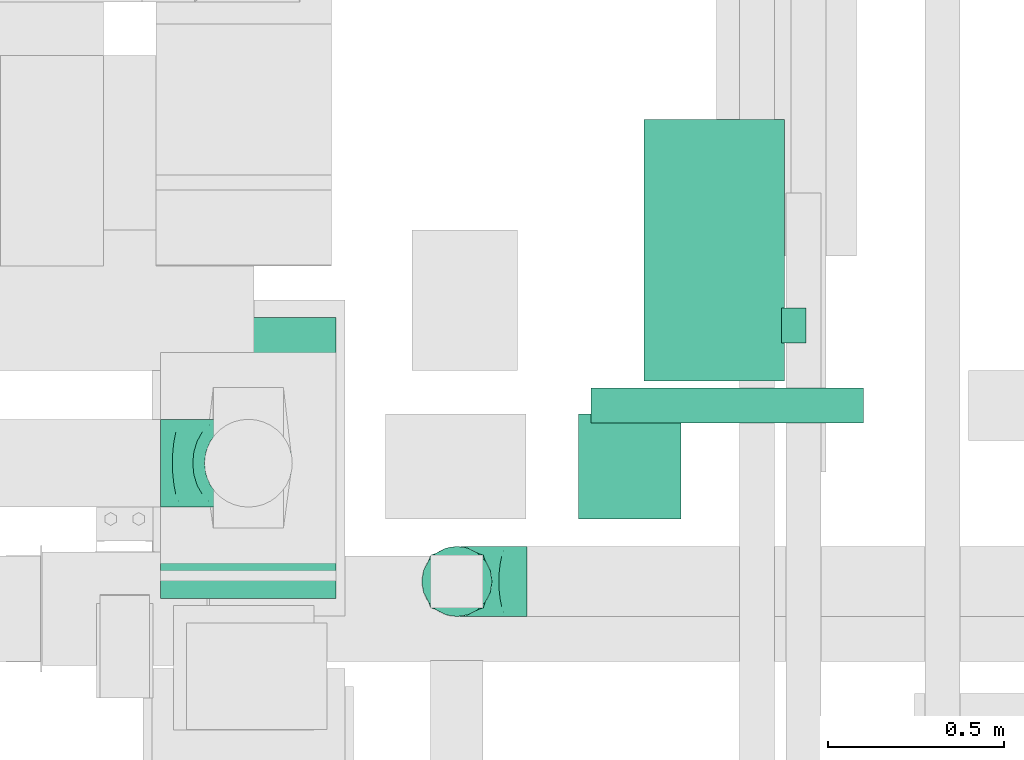
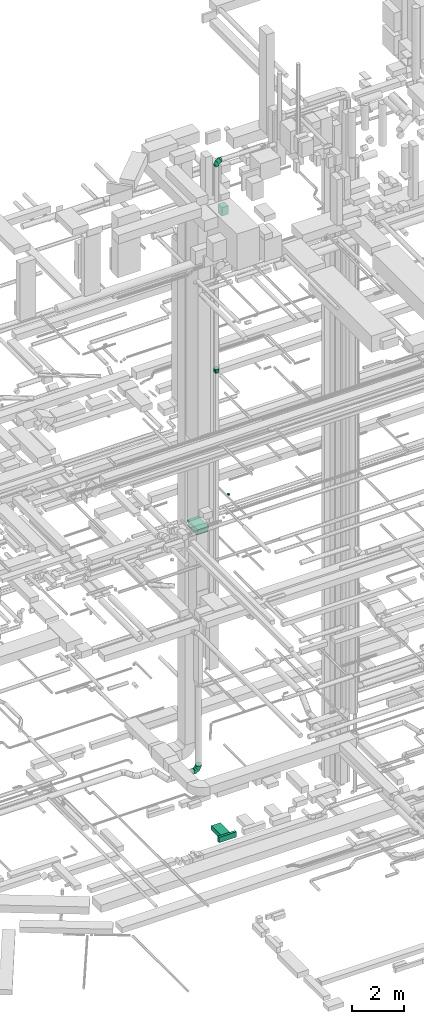
# One storey, part 129 of 337: 4 flow fittings, 4 flow segments.
"""IFC2X3 building model written with IfcOpenShell, lengths in millimetres."""

from ifc_helpers import new_model, entity, si_unit, converted_unit, derived_unit, direction, frame, origin, origin_2d_with_axis, place, context, subcontext, project, spatial, polyline, rectangle, circle, outline, extrude, faceted_brep, source, transform, mapped, material, type_object, type_shapes, element, save


model = new_model("IFC2X3")

# Units and contexts
model_context = context("Model", 3, precision=0.01, world=origin(), true_north=direction((6.12303176911189e-17, 1.0)))
body_context = subcontext(model_context, "Body", "Model", "MODEL_VIEW")
ifc_project = project(units=[si_unit("LENGTHUNIT", "METRE", prefix="MILLI"), si_unit("AREAUNIT", "SQUARE_METRE"), si_unit("VOLUMEUNIT", "CUBIC_METRE"), converted_unit("PLANEANGLEUNIT", "DEGREE", entity("IfcRatioMeasure", 0.0174532925199433), si_unit("PLANEANGLEUNIT", "RADIAN"), dimensions=[0, 0, 0, 0, 0, 0, 0]), si_unit("MASSUNIT", "GRAM", prefix="KILO"), derived_unit("MASSDENSITYUNIT", [(si_unit("MASSUNIT", "GRAM", prefix="KILO"), 1), (si_unit("LENGTHUNIT", "METRE"), -3)]), derived_unit("MOMENTOFINERTIAUNIT", [(si_unit("LENGTHUNIT", "METRE"), 4)]), si_unit("TIMEUNIT", "SECOND"), si_unit("FREQUENCYUNIT", "HERTZ"), si_unit("THERMODYNAMICTEMPERATUREUNIT", "DEGREE_CELSIUS"), derived_unit("THERMALTRANSMITTANCEUNIT", [(si_unit("MASSUNIT", "GRAM", prefix="KILO"), 1), (si_unit("THERMODYNAMICTEMPERATUREUNIT", "KELVIN"), -1), (si_unit("TIMEUNIT", "SECOND"), -3)]), derived_unit("VOLUMETRICFLOWRATEUNIT", [(si_unit("LENGTHUNIT", "METRE"), 3), (si_unit("TIMEUNIT", "SECOND"), -1)]), derived_unit("MASSFLOWRATEUNIT", [(si_unit("MASSUNIT", "GRAM", prefix="KILO"), 1), (si_unit("TIMEUNIT", "SECOND"), -1)]), derived_unit("ROTATIONALFREQUENCYUNIT", [(si_unit("TIMEUNIT", "SECOND"), -1)]), si_unit("ELECTRICCURRENTUNIT", "AMPERE"), si_unit("ELECTRICVOLTAGEUNIT", "VOLT"), si_unit("POWERUNIT", "WATT"), si_unit("FORCEUNIT", "NEWTON", prefix="KILO"), si_unit("ILLUMINANCEUNIT", "LUX"), si_unit("LUMINOUSFLUXUNIT", "LUMEN"), si_unit("LUMINOUSINTENSITYUNIT", "CANDELA"), derived_unit("USERDEFINED", [(si_unit("MASSUNIT", "GRAM", prefix="KILO"), -1), (si_unit("LENGTHUNIT", "METRE"), -2), (si_unit("TIMEUNIT", "SECOND"), 3), (si_unit("LUMINOUSFLUXUNIT", "LUMEN"), 1)]), derived_unit("LINEARVELOCITYUNIT", [(si_unit("LENGTHUNIT", "METRE"), 1), (si_unit("TIMEUNIT", "SECOND"), -1)]), si_unit("PRESSUREUNIT", "PASCAL"), derived_unit("USERDEFINED", [(si_unit("LENGTHUNIT", "METRE"), -2), (si_unit("MASSUNIT", "GRAM", prefix="KILO"), 1), (si_unit("TIMEUNIT", "SECOND"), -2)]), derived_unit("LINEARFORCEUNIT", [(si_unit("MASSUNIT", "GRAM", prefix="KILO"), 1), (si_unit("LENGTHUNIT", "METRE"), 1), (si_unit("TIMEUNIT", "SECOND"), -2), (si_unit("LENGTHUNIT", "METRE"), -1)]), derived_unit("PLANARFORCEUNIT", [(si_unit("MASSUNIT", "GRAM", prefix="KILO"), 1), (si_unit("LENGTHUNIT", "METRE"), 1), (si_unit("TIMEUNIT", "SECOND"), -2), (si_unit("LENGTHUNIT", "METRE"), -2)])], contexts=[model_context])

# Site, building, storey
site_placement = place(None, origin())
site = spatial("IfcSite", under=ifc_project, at=site_placement, CompositionType="ELEMENT")
building_placement = place(site_placement, origin())
building = spatial("IfcBuilding", under=site, at=building_placement, CompositionType="ELEMENT")
storey_placement = place(building_placement, origin())
storey = spatial("IfcBuildingStorey", under=building, at=storey_placement, CompositionType="ELEMENT", Elevation=0.0)

# Flow segments
duct_segment_type_1 = type_object("IfcDuctSegmentType", PredefinedType="NOTDEFINED")
flow_segment_1_placement = place(storey_placement, frame((25317.74, 11348.59, -875.0)))
element("IfcFlowSegment", 1, at=flow_segment_1_placement, inside=storey, type_object=duct_segment_type_1, context=body_context, shape_type="SweptSolid", body=[
    extrude(rectangle(XDim=776.396494937963, YDim=100.000000000001, at=origin_2d_with_axis()), frame((388.2, 50.0, 0.0), z_axis=(0.0, 0.0, 1.0), x_axis=(-1.0, 0.0, 0.0)), (0.0, 0.0, 1.0), 250.0),
])
flow_segment_2_placement = place(storey_placement, frame((25469.82, 11468.59, -850.0)))
element("IfcFlowSegment", 2, at=flow_segment_2_placement, inside=storey, type_object=duct_segment_type_1, context=body_context, shape_type="SweptSolid", body=[
    extrude(rectangle(XDim=744.999999999924, YDim=400.0, at=origin_2d_with_axis()), frame((200.0, 372.5, 0.0), z_axis=(0.0, 0.0, 1.0), x_axis=(0.0, 1.0, 0.0)), (0.0, 0.0, 1.0), 200.0),
])
flow_segment_3_placement = place(storey_placement, frame((25283.23, 11074.99, 28600.0)))
element("IfcFlowSegment", 3, at=flow_segment_3_placement, inside=storey, type_object=duct_segment_type_1, context=body_context, shape_type="SweptSolid", body=[
    extrude(rectangle(XDim=291.800500523164, YDim=300.000000000001, at=origin_2d_with_axis()), frame((145.9, 150.0, 0.0), z_axis=(0.0, 0.0, 1.0), x_axis=(-1.0, 0.0, 0.0)), (0.0, 0.0, 1.0), 399.999999999996),
])
duct_segment_type_2 = type_object("IfcDuctSegmentType", PredefinedType="NOTDEFINED")
flow_segment_4_placement = place(storey_placement, frame((25860.75, 11574.71, 14998.4)))
element("IfcFlowSegment", 4, at=flow_segment_4_placement, inside=storey, type_object=duct_segment_type_2, context=body_context, shape_type="SweptSolid", body=[
    extrude(circle(Radius=50.0, at=origin_2d_with_axis()), frame((0.0, 51.6, 51.6), z_axis=(1.0, 0.0, 0.0), x_axis=(0.0, -1.0, 0.0)), (0.0, 0.0, 1.0), 69.9999999999668),
])

# Flow fittings
ifc_material = material()
duct_fitting_type_1 = type_object("IfcDuctFittingType", PredefinedType="NOTDEFINED", material=ifc_material)
shared_shape_1 = source(origin(), body_context, "Body", "SweptSolid", [
    extrude(outline(polyline([(-47.43, -332.04), (268.79, -332.04), (15.81, 426.91), (-237.17, 237.17), (-47.43, -332.04)])), frame((150.0, 0.0, -250.0), z_axis=(-3.31555884537689e-05, 0.0, 1.0), x_axis=(0.948683297581217, -0.316227765860407, 3.14541530048558e-05)), (3.14541530048558e-05, 1.04847176625225e-05, 1.0), 500.0),
])
type_shapes(duct_fitting_type_1, [shared_shape_1])
flow_fitting_1_placement = place(storey_placement, frame((24342.12, 11249.36, 14190.0), z_axis=(-1.0, 0.0, 0.0), x_axis=(0.0, 0.0, 1.0)))
element("IfcFlowFitting", 5, at=flow_fitting_1_placement, inside=storey, type_object=duct_fitting_type_1, material=ifc_material, context=body_context, shape_type="MappedRepresentation", body=[
    mapped(shared_shape_1, transform((0.0, 0.0, 0.0), scale=1.0)),
])
duct_fitting_type_2 = type_object("IfcDuctFittingType", PredefinedType="NOTDEFINED", material=ifc_material)
shared_shape_2 = source(origin(), body_context, "Body", "Brep", [
    faceted_brep([(-250.0, 0.0, -125.0), (-250.0, -32.35, -120.74), (-250.0, -62.5, -108.25), (-250.0, -88.39, -88.39), (-250.0, -108.25, -62.5), (-250.0, -120.74, -32.35), (-250.0, -125.0, 0.0), (-250.0, -120.74, 32.35), (-250.0, -108.25, 62.5), (-250.0, -88.39, 88.39), (-250.0, -62.5, 108.25), (-250.0, -32.35, 120.74), (-250.0, 0.0, 125.0), (-250.0, 32.35, 120.74), (-250.0, 62.5, 108.25), (-250.0, 88.39, 88.39), (-250.0, 108.25, 62.5), (-250.0, 120.74, 32.35), (-250.0, 125.0, 0.0), (-250.0, 120.74, -32.35), (-250.0, 108.25, -62.5), (-250.0, 88.39, -88.39), (-250.0, 62.5, -108.25), (-250.0, 32.35, -120.74), (-191.68, 32.35, 120.74), (-199.76, 62.5, 108.25), (-183.01, 0.0, 125.0), (-206.7, 88.39, 88.39), (-215.37, 120.74, 32.35), (-216.51, 125.0, 0.0), (-212.02, 108.25, 62.5), (-212.02, 108.25, -62.5), (-206.7, 88.39, -88.39), (-215.37, 120.74, -32.35), (-191.68, 32.35, -120.74), (-183.01, 0.0, -125.0), (-199.76, 62.5, -108.25), (-174.34, -32.35, -120.74), (-166.27, -62.5, -108.25), (-159.33, -88.39, -88.39), (-154.01, -108.25, -62.5), (-150.66, -120.74, -32.35), (-149.52, -125.0, 0.0), (-150.66, -120.74, 32.35), (-154.01, -108.25, 62.5), (-159.33, -88.39, 88.39), (-166.27, -62.5, 108.25), (-174.34, -32.35, 120.74), (-90.67, 90.67, 120.74), (-112.74, 112.74, 108.25), (-66.99, 66.99, 125.0), (-131.69, 131.69, 88.39), (-146.23, 146.23, 62.5), (-155.38, 155.38, 32.35), (-158.49, 158.49, 0.0), (-155.38, 155.38, -32.35), (-146.23, 146.23, -62.5), (-131.69, 131.69, -88.39), (-90.67, 90.67, -120.74), (-66.99, 66.99, -125.0), (-112.74, 112.74, -108.25), (-43.3, 43.3, -120.74), (-21.23, 21.23, -108.25), (-2.28, 2.28, -88.39), (12.26, -12.26, -62.5), (21.4, -21.4, -32.35), (24.52, -24.52, 0.0), (21.4, -21.4, 32.35), (12.26, -12.26, 62.5), (-2.28, 2.28, 88.39), (-21.23, 21.23, 108.25), (-43.3, 43.3, 120.74), (-32.35, 191.68, 120.74), (-62.5, 199.76, 108.25), (0.0, 183.01, 125.0), (-88.39, 206.7, 88.39), (-108.25, 212.02, 62.5), (-120.74, 215.37, 32.35), (-125.0, 216.51, 0.0), (-120.74, 215.37, -32.35), (-108.25, 212.02, -62.5), (-88.39, 206.7, -88.39), (-32.35, 191.68, -120.74), (0.0, 183.01, -125.0), (-62.5, 199.76, -108.25), (32.35, 174.34, -120.74), (62.5, 166.27, -108.25), (88.39, 159.33, -88.39), (108.25, 154.01, -62.5), (120.74, 150.66, -32.35), (125.0, 149.52, 0.0), (120.74, 150.66, 32.35), (108.25, 154.01, 62.5), (88.39, 159.33, 88.39), (62.5, 166.27, 108.25), (32.35, 174.34, 120.74), (-32.35, 250.0, -120.74), (-62.5, 250.0, -108.25), (-88.39, 250.0, -88.39), (-108.25, 250.0, -62.5), (-120.74, 250.0, -32.35), (-125.0, 250.0, 0.0), (-120.74, 250.0, 32.35), (-108.25, 250.0, 62.5), (-88.39, 250.0, 88.39), (-62.5, 250.0, 108.25), (-32.35, 250.0, 120.74), (0.0, 250.0, 125.0), (32.35, 250.0, 120.74), (62.5, 250.0, 108.25), (88.39, 250.0, 88.39), (108.25, 250.0, 62.5), (120.74, 250.0, 32.35), (125.0, 250.0, 0.0), (120.74, 250.0, -32.35), (108.25, 250.0, -62.5), (88.39, 250.0, -88.39), (62.5, 250.0, -108.25), (32.35, 250.0, -120.74), (0.0, 250.0, -125.0)], [[[0, 1, 2, 3, 4, 5, 6, 7, 8, 9, 10, 11, 12, 13, 14, 15, 16, 17, 18, 19, 20, 21, 22, 23]], [[24, 25, 14, 13]], [[26, 24, 13, 12]], [[14, 25, 27, 15]], [[28, 29, 18, 17]], [[30, 28, 17, 16]], [[15, 27, 30, 16]], [[20, 31, 32, 21]], [[33, 31, 20, 19]], [[18, 29, 33, 19]], [[34, 35, 0, 23]], [[36, 34, 23, 22]], [[21, 32, 36, 22]], [[1, 0, 35, 37]], [[2, 1, 37, 38]], [[38, 39, 3, 2]], [[5, 4, 40, 41]], [[6, 5, 41, 42]], [[39, 40, 4, 3]], [[6, 42, 43, 7]], [[7, 43, 44, 8]], [[8, 44, 45, 9]], [[9, 45, 46, 10]], [[10, 46, 47, 11]], [[26, 12, 11, 47]], [[48, 49, 25, 24]], [[50, 48, 24, 26]], [[27, 25, 49, 51]], [[52, 53, 28, 30]], [[51, 52, 30, 27]], [[29, 28, 53, 54]], [[55, 56, 31, 33]], [[54, 55, 33, 29]], [[32, 31, 56, 57]], [[58, 59, 35, 34]], [[60, 58, 34, 36]], [[57, 60, 36, 32]], [[37, 35, 59, 61]], [[38, 37, 61, 62]], [[39, 38, 62, 63]], [[41, 40, 64, 65]], [[42, 41, 65, 66]], [[63, 64, 40, 39]], [[43, 42, 66, 67]], [[44, 43, 67, 68]], [[68, 69, 45, 44]], [[46, 45, 69, 70]], [[47, 46, 70, 71]], [[26, 47, 71, 50]], [[72, 73, 49, 48]], [[74, 72, 48, 50]], [[51, 49, 73, 75]], [[76, 77, 53, 52]], [[75, 76, 52, 51]], [[54, 53, 77, 78]], [[79, 80, 56, 55]], [[78, 79, 55, 54]], [[57, 56, 80, 81]], [[82, 83, 59, 58]], [[84, 82, 58, 60]], [[81, 84, 60, 57]], [[61, 59, 83, 85]], [[62, 61, 85, 86]], [[63, 62, 86, 87]], [[65, 64, 88, 89]], [[66, 65, 89, 90]], [[87, 88, 64, 63]], [[67, 66, 90, 91]], [[68, 67, 91, 92]], [[92, 93, 69, 68]], [[70, 69, 93, 94]], [[71, 70, 94, 95]], [[50, 71, 95, 74]], [[96, 97, 98, 99, 100, 101, 102, 103, 104, 105, 106, 107, 108, 109, 110, 111, 112, 113, 114, 115, 116, 117, 118, 119]], [[72, 74, 107, 106]], [[73, 72, 106, 105]], [[75, 73, 105, 104]], [[77, 76, 103, 102]], [[78, 77, 102, 101]], [[75, 104, 103, 76]], [[78, 101, 100, 79]], [[79, 100, 99, 80]], [[80, 99, 98, 81]], [[84, 97, 96, 82]], [[82, 96, 119, 83]], [[84, 81, 98, 97]], [[83, 119, 118, 85]], [[85, 118, 117, 86]], [[116, 87, 86, 117]], [[88, 115, 114, 89]], [[89, 114, 113, 90]], [[115, 88, 87, 116]], [[91, 90, 113, 112]], [[92, 91, 112, 111]], [[111, 110, 93, 92]], [[95, 94, 109, 108]], [[74, 95, 108, 107]], [[110, 109, 94, 93]]]),
])
type_shapes(duct_fitting_type_2, [shared_shape_2])
flow_fitting_2_placement = place(storey_placement, frame((24342.3, 11234.36, 2970.0), z_axis=(0.0, -1.0, 0.0), x_axis=(1.0, 0.0, 0.0)))
element("IfcFlowFitting", 6, at=flow_fitting_2_placement, inside=storey, type_object=duct_fitting_type_2, material=ifc_material, context=body_context, shape_type="MappedRepresentation", body=[
    mapped(shared_shape_2, transform((0.0, 0.0, 0.0), scale=1.0)),
])
duct_fitting_type_3 = type_object("IfcDuctFittingType", PredefinedType="NOTDEFINED", material=ifc_material)
shared_shape_3 = source(origin(), body_context, "Body", "Brep", [
    faceted_brep([(-200.0, 0.0, -100.0), (-200.0, -25.88, -96.59), (-200.0, -50.0, -86.6), (-200.0, -70.71, -70.71), (-200.0, -86.6, -50.0), (-200.0, -96.59, -25.88), (-200.0, -100.0, 0.0), (-200.0, -96.59, 25.88), (-200.0, -86.6, 50.0), (-200.0, -70.71, 70.71), (-200.0, -50.0, 86.6), (-200.0, -25.88, 96.59), (-200.0, 0.0, 100.0), (-200.0, 25.88, 96.59), (-200.0, 50.0, 86.6), (-200.0, 70.71, 70.71), (-200.0, 86.6, 50.0), (-200.0, 96.59, 25.88), (-200.0, 100.0, 0.0), (-200.0, 96.59, -25.88), (-200.0, 86.6, -50.0), (-200.0, 70.71, -70.71), (-200.0, 50.0, -86.6), (-200.0, 25.88, -96.59), (-153.35, 25.88, 96.59), (-159.81, 50.0, 86.6), (-146.41, 0.0, 100.0), (-165.36, 70.71, 70.71), (-172.29, 96.59, 25.88), (-173.21, 100.0, 0.0), (-169.62, 86.6, 50.0), (-169.62, 86.6, -50.0), (-165.36, 70.71, -70.71), (-172.29, 96.59, -25.88), (-153.35, 25.88, -96.59), (-146.41, 0.0, -100.0), (-159.81, 50.0, -86.6), (-139.48, -25.88, -96.59), (-133.01, -50.0, -86.6), (-127.46, -70.71, -70.71), (-123.21, -86.6, -50.0), (-120.53, -96.59, -25.88), (-119.62, -100.0, 0.0), (-120.53, -96.59, 25.88), (-123.21, -86.6, 50.0), (-127.46, -70.71, 70.71), (-133.01, -50.0, 86.6), (-139.48, -25.88, 96.59), (-72.54, 72.54, 96.59), (-90.19, 90.19, 86.6), (-53.59, 53.59, 100.0), (-105.35, 105.35, 70.71), (-116.99, 116.99, 50.0), (-124.3, 124.3, 25.88), (-126.79, 126.79, 0.0), (-124.3, 124.3, -25.88), (-116.99, 116.99, -50.0), (-105.35, 105.35, -70.71), (-72.54, 72.54, -96.59), (-53.59, 53.59, -100.0), (-90.19, 90.19, -86.6), (-34.64, 34.64, -96.59), (-16.99, 16.99, -86.6), (-1.83, 1.83, -70.71), (9.81, -9.81, -50.0), (17.12, -17.12, -25.88), (19.62, -19.62, 0.0), (17.12, -17.12, 25.88), (9.81, -9.81, 50.0), (-1.83, 1.83, 70.71), (-16.99, 16.99, 86.6), (-34.64, 34.64, 96.59), (-25.88, 153.35, 96.59), (-50.0, 159.81, 86.6), (0.0, 146.41, 100.0), (-70.71, 165.36, 70.71), (-86.6, 169.62, 50.0), (-96.59, 172.29, 25.88), (-100.0, 173.21, 0.0), (-96.59, 172.29, -25.88), (-86.6, 169.62, -50.0), (-70.71, 165.36, -70.71), (-25.88, 153.35, -96.59), (0.0, 146.41, -100.0), (-50.0, 159.81, -86.6), (25.88, 139.48, -96.59), (50.0, 133.01, -86.6), (70.71, 127.46, -70.71), (86.6, 123.21, -50.0), (96.59, 120.53, -25.88), (100.0, 119.62, 0.0), (96.59, 120.53, 25.88), (86.6, 123.21, 50.0), (70.71, 127.46, 70.71), (50.0, 133.01, 86.6), (25.88, 139.48, 96.59), (-25.88, 200.0, -96.59), (-50.0, 200.0, -86.6), (-70.71, 200.0, -70.71), (-86.6, 200.0, -50.0), (-96.59, 200.0, -25.88), (-100.0, 200.0, 0.0), (-96.59, 200.0, 25.88), (-86.6, 200.0, 50.0), (-70.71, 200.0, 70.71), (-50.0, 200.0, 86.6), (-25.88, 200.0, 96.59), (0.0, 200.0, 100.0), (25.88, 200.0, 96.59), (50.0, 200.0, 86.6), (70.71, 200.0, 70.71), (86.6, 200.0, 50.0), (96.59, 200.0, 25.88), (100.0, 200.0, 0.0), (96.59, 200.0, -25.88), (86.6, 200.0, -50.0), (70.71, 200.0, -70.71), (50.0, 200.0, -86.6), (25.88, 200.0, -96.59), (0.0, 200.0, -100.0)], [[[0, 1, 2, 3, 4, 5, 6, 7, 8, 9, 10, 11, 12, 13, 14, 15, 16, 17, 18, 19, 20, 21, 22, 23]], [[24, 25, 14, 13]], [[26, 24, 13, 12]], [[14, 25, 27, 15]], [[28, 29, 18, 17]], [[30, 28, 17, 16]], [[15, 27, 30, 16]], [[20, 31, 32, 21]], [[33, 31, 20, 19]], [[18, 29, 33, 19]], [[34, 35, 0, 23]], [[36, 34, 23, 22]], [[32, 36, 22, 21]], [[1, 0, 35, 37]], [[2, 1, 37, 38]], [[38, 39, 3, 2]], [[5, 4, 40, 41]], [[6, 5, 41, 42]], [[39, 40, 4, 3]], [[6, 42, 43, 7]], [[7, 43, 44, 8]], [[8, 44, 45, 9]], [[9, 45, 46, 10]], [[10, 46, 47, 11]], [[26, 12, 11, 47]], [[48, 49, 25, 24]], [[50, 48, 24, 26]], [[27, 25, 49, 51]], [[52, 53, 28, 30]], [[51, 52, 30, 27]], [[29, 28, 53, 54]], [[55, 56, 31, 33]], [[54, 55, 33, 29]], [[32, 31, 56, 57]], [[58, 59, 35, 34]], [[60, 58, 34, 36]], [[57, 60, 36, 32]], [[37, 35, 59, 61]], [[38, 37, 61, 62]], [[39, 38, 62, 63]], [[41, 40, 64, 65]], [[42, 41, 65, 66]], [[63, 64, 40, 39]], [[43, 42, 66, 67]], [[44, 43, 67, 68]], [[68, 69, 45, 44]], [[46, 45, 69, 70]], [[47, 46, 70, 71]], [[26, 47, 71, 50]], [[72, 73, 49, 48]], [[74, 72, 48, 50]], [[51, 49, 73, 75]], [[76, 77, 53, 52]], [[75, 76, 52, 51]], [[54, 53, 77, 78]], [[79, 80, 56, 55]], [[78, 79, 55, 54]], [[57, 56, 80, 81]], [[82, 83, 59, 58]], [[84, 82, 58, 60]], [[81, 84, 60, 57]], [[61, 59, 83, 85]], [[62, 61, 85, 86]], [[63, 62, 86, 87]], [[65, 64, 88, 89]], [[66, 65, 89, 90]], [[87, 88, 64, 63]], [[67, 66, 90, 91]], [[68, 67, 91, 92]], [[92, 93, 69, 68]], [[70, 69, 93, 94]], [[71, 70, 94, 95]], [[50, 71, 95, 74]], [[96, 97, 98, 99, 100, 101, 102, 103, 104, 105, 106, 107, 108, 109, 110, 111, 112, 113, 114, 115, 116, 117, 118, 119]], [[72, 74, 107, 106]], [[73, 72, 106, 105]], [[75, 73, 105, 104]], [[102, 101, 78, 77]], [[103, 102, 77, 76]], [[75, 104, 103, 76]], [[78, 101, 100, 79]], [[79, 100, 99, 80]], [[80, 99, 98, 81]], [[84, 97, 96, 82]], [[82, 96, 119, 83]], [[84, 81, 98, 97]], [[118, 117, 86, 85]], [[119, 118, 85, 83]], [[116, 87, 86, 117]], [[88, 115, 114, 89]], [[89, 114, 113, 90]], [[115, 88, 87, 116]], [[91, 90, 113, 112]], [[92, 91, 112, 111]], [[111, 110, 93, 92]], [[95, 94, 109, 108]], [[74, 95, 108, 107]], [[110, 109, 94, 93]]]),
])
type_shapes(duct_fitting_type_3, [shared_shape_3])
flow_fitting_3_placement = place(storey_placement, frame((24936.21, 10897.55, 31410.11), z_axis=(0.0, 1.0, 0.0), x_axis=(0.0, 0.0, 1.0)))
element("IfcFlowFitting", 7, at=flow_fitting_3_placement, inside=storey, type_object=duct_fitting_type_3, material=ifc_material, context=body_context, shape_type="MappedRepresentation", body=[
    mapped(shared_shape_3, transform((0.0, 0.0, 0.0), scale=1.0)),
])
duct_fitting_type_4 = type_object("IfcDuctFittingType", PredefinedType="NOTDEFINED", material=ifc_material)
shared_shape_4 = source(origin(), body_context, "Body", "Brep", [
    faceted_brep([(200.0, 30.9, 95.11), (200.0, 19.08, 96.98), (200.0, 9.54, 98.49), (200.0, 4.77, 99.24), (200.0, 0.0, 100.0), (200.0, -4.77, 99.24), (200.0, -9.54, 98.49), (200.0, -19.08, 96.98), (200.0, -30.9, 95.11), (200.0, -44.84, 88.0), (200.0, -58.78, 80.9), (200.0, -69.84, 69.84), (200.0, -80.9, 58.78), (200.0, -88.0, 44.84), (200.0, -95.11, 30.9), (200.0, -96.98, 19.08), (200.0, -98.49, 9.54), (200.0, -99.24, 4.77), (200.0, -100.0, 0.0), (200.0, -99.24, -4.77), (200.0, -98.49, -9.54), (200.0, -96.98, -19.08), (200.0, -95.11, -30.9), (200.0, -88.0, -44.84), (200.0, -80.9, -58.78), (200.0, -69.84, -69.84), (200.0, -58.78, -80.9), (200.0, -44.84, -88.0), (200.0, -30.9, -95.11), (200.0, -19.08, -96.98), (200.0, -9.54, -98.49), (200.0, -4.77, -99.24), (200.0, 0.0, -100.0), (200.0, 4.77, -99.24), (200.0, 9.54, -98.49), (200.0, 19.08, -96.98), (200.0, 30.9, -95.11), (200.0, 44.84, -88.0), (200.0, 58.78, -80.9), (200.0, 69.84, -69.84), (200.0, 80.9, -58.78), (200.0, 88.0, -44.84), (200.0, 95.11, -30.9), (200.0, 96.98, -19.08), (200.0, 98.49, -9.54), (200.0, 99.24, -4.77), (200.0, 100.0, 0.0), (200.0, 99.24, 4.77), (200.0, 98.49, 9.54), (200.0, 96.98, 19.08), (200.0, 95.11, 30.9), (200.0, 88.0, 44.84), (200.0, 80.9, 58.78), (200.0, 69.84, 69.84), (200.0, 58.78, 80.9), (200.0, 44.84, 88.0), (0.0, -75.0, 75.0), (0.0, 75.0, 75.0), (0.0, 75.0, -75.0), (0.0, -75.0, -75.0), (104.11, -35.96, 88.01), (100.0, -70.65, 74.93), (26.03, -65.24, 78.25), (78.09, -45.72, 84.76), (52.06, -55.48, 81.51), (188.01, -4.49, 98.5), (176.03, -8.99, 97.0), (152.06, -17.98, 94.01), (128.09, -26.97, 91.01), (52.06, -81.51, 55.48), (78.09, -84.76, 45.72), (104.11, -88.01, 35.96), (128.09, -91.01, 26.97), (152.06, -94.01, 17.98), (176.03, -97.0, 8.99), (188.01, -98.5, 4.49), (26.03, -78.25, 65.24), (26.03, -78.25, -65.24), (52.06, -81.51, -55.48), (78.09, -84.76, -45.72), (104.11, -88.01, -35.96), (128.09, -91.01, -26.97), (152.06, -94.01, -17.98), (176.03, -97.0, -8.99), (188.01, -98.5, -4.49), (100.0, -74.93, -70.65), (52.06, -55.48, -81.51), (78.09, -45.72, -84.76), (104.11, -35.96, -88.01), (128.09, -26.97, -91.01), (152.06, -17.98, -94.01), (176.03, -8.99, -97.0), (188.01, -4.49, -98.5), (26.03, -65.24, -78.25), (26.03, 65.24, -78.25), (52.06, 55.48, -81.51), (78.09, 45.72, -84.76), (104.11, 35.96, -88.01), (128.09, 26.97, -91.01), (152.06, 17.98, -94.01), (176.03, 8.99, -97.0), (188.01, 4.49, -98.5), (100.0, 70.65, -74.93), (52.06, 81.51, -55.48), (78.09, 84.76, -45.72), (104.11, 88.01, -35.96), (128.09, 91.01, -26.97), (152.06, 94.01, -17.98), (176.03, 97.0, -8.99), (188.01, 98.5, -4.49), (26.03, 78.25, -65.24), (26.03, 78.25, 65.24), (52.06, 81.51, 55.48), (78.09, 84.76, 45.72), (104.11, 88.01, 35.96), (128.09, 91.01, 26.97), (152.06, 94.01, 17.98), (176.03, 97.0, 8.99), (188.01, 98.5, 4.49), (100.0, 74.93, 70.65), (52.06, 55.48, 81.51), (78.09, 45.72, 84.76), (104.11, 35.96, 88.01), (128.09, 26.97, 91.01), (152.06, 17.98, 94.01), (176.03, 8.99, 97.0), (188.01, 4.49, 98.5), (26.03, 65.24, 78.25)], [[[0, 1, 2, 3, 4, 5, 6, 7, 8, 9, 10, 11, 12, 13, 14, 15, 16, 17, 18, 19, 20, 21, 22, 23, 24, 25, 26, 27, 28, 29, 30, 31, 32, 33, 34, 35, 36, 37, 38, 39, 40, 41, 42, 43, 44, 45, 46, 47, 48, 49, 50, 51, 52, 53, 54, 55]], [[56, 57, 58, 59]], [[60, 9, 8]], [[56, 61, 62]], [[9, 60, 63, 64]], [[65, 66, 67, 68, 60, 8, 7, 6, 5, 4]], [[62, 61, 10]], [[13, 69, 70, 71]], [[64, 10, 9]], [[14, 71, 72, 73, 74, 75, 18, 17, 16, 15]], [[12, 76, 69]], [[71, 14, 13]], [[61, 76, 11]], [[10, 64, 62]], [[76, 12, 11]], [[10, 61, 11]], [[61, 56, 76]], [[69, 13, 12]], [[75, 74, 73, 72, 71, 70, 69, 76, 56, 59, 77, 78, 79, 80, 81, 82, 83, 84, 18]], [[80, 23, 22]], [[59, 85, 77]], [[23, 80, 79, 78]], [[84, 83, 82, 81, 80, 22, 21, 20, 19, 18]], [[77, 85, 24]], [[27, 86, 87, 88]], [[78, 24, 23]], [[28, 88, 89, 90, 91, 92, 32, 31, 30, 29]], [[26, 93, 86]], [[88, 28, 27]], [[85, 93, 25]], [[24, 78, 77]], [[93, 26, 25]], [[24, 85, 25]], [[85, 59, 93]], [[86, 27, 26]], [[92, 91, 90, 89, 88, 87, 86, 93, 59, 58, 94, 95, 96, 97, 98, 99, 100, 101, 32]], [[97, 37, 36]], [[58, 102, 94]], [[37, 97, 96, 95]], [[101, 100, 99, 98, 97, 36, 35, 34, 33, 32]], [[94, 102, 38]], [[41, 103, 104, 105]], [[95, 38, 37]], [[42, 105, 106, 107, 108, 109, 46, 45, 44, 43]], [[40, 110, 103]], [[105, 42, 41]], [[102, 110, 39]], [[38, 95, 94]], [[110, 40, 39]], [[38, 102, 39]], [[102, 58, 110]], [[103, 41, 40]], [[58, 57, 111, 112, 113, 114, 115, 116, 117, 118, 46, 109, 108, 107, 106, 105, 104, 103, 110]], [[114, 51, 50]], [[57, 119, 111]], [[51, 114, 113, 112]], [[118, 117, 116, 115, 114, 50, 49, 48, 47, 46]], [[111, 119, 52]], [[55, 120, 121, 122]], [[112, 52, 51]], [[0, 122, 123, 124, 125, 126, 4, 3, 2, 1]], [[54, 127, 120]], [[122, 0, 55]], [[119, 127, 53]], [[52, 112, 111]], [[127, 54, 53]], [[52, 119, 53]], [[119, 57, 127]], [[120, 55, 54]], [[57, 56, 62, 64, 63, 60, 68, 67, 66, 65, 4, 126, 125, 124, 123, 122, 121, 120, 127]]]),
])
type_shapes(duct_fitting_type_4, [shared_shape_4])
flow_fitting_4_placement = place(storey_placement, frame((24936.21, 10897.55, 21542.0), z_axis=(0.0, 1.0, 0.0), x_axis=(0.0, 0.0, 1.0)))
element("IfcFlowFitting", 8, at=flow_fitting_4_placement, inside=storey, type_object=duct_fitting_type_4, material=ifc_material, context=body_context, shape_type="MappedRepresentation", body=[
    mapped(shared_shape_4, transform((0.0, 0.0, 0.0), scale=1.0)),
])

save(model, "model.ifc")
